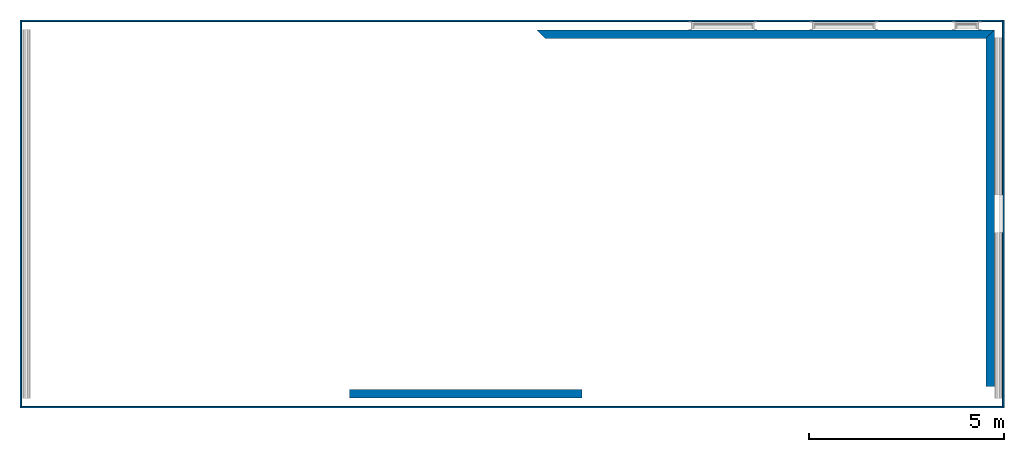
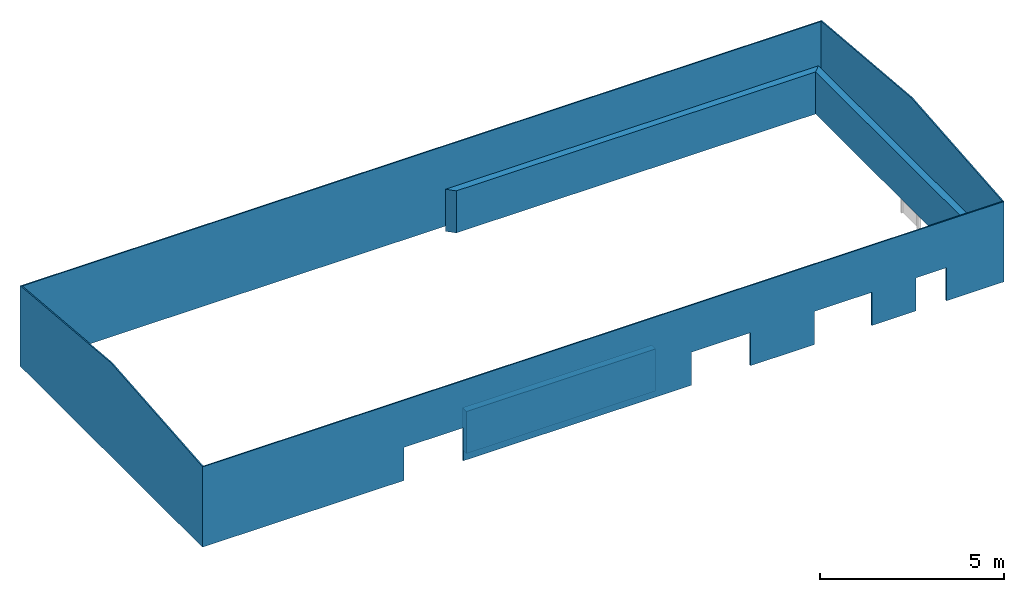
# One storey, part 2 of 4: 7 walls, 8 openings.
"""IFC2X3 building model written with IfcOpenShell, lengths in millimetres."""

from ifc_helpers import new_model, entity, si_unit, converted_unit, money_unit, direction, frame, origin_with_axes, place, context, subcontext, project, spatial, polyline, outline, extrude, clip, halfspace, material, layer, layer_set, layer_usage, type_object, element, save


model = new_model("IFC2X3")

# Units and contexts
model_context = context("Model", 3, precision=1e-05, world=origin_with_axes(), true_north=direction((0.0, 1.0)))
body_context = subcontext(model_context, "Body", "Model", "MODEL_VIEW")
ifc_project = project(units=[si_unit("LENGTHUNIT", "METRE", prefix="MILLI"), si_unit("AREAUNIT", "SQUARE_METRE"), si_unit("VOLUMEUNIT", "CUBIC_METRE"), converted_unit("PLANEANGLEUNIT", "DEGREE", entity("IfcPlaneAngleMeasure", 0.0174532925199), si_unit("PLANEANGLEUNIT", "RADIAN"), dimensions=[0, 0, 0, 0, 0, 0, 0]), si_unit("SOLIDANGLEUNIT", "STERADIAN"), money_unit("USD"), converted_unit("TIMEUNIT", "Year", entity("IfcTimeMeasure", 31556926.0), si_unit("TIMEUNIT", "SECOND"), dimensions=[0, 0, 0, 0, 0, 0, 0]), si_unit("MASSUNIT", "GRAM"), si_unit("THERMODYNAMICTEMPERATUREUNIT", "DEGREE_CELSIUS"), si_unit("LUMINOUSINTENSITYUNIT", "LUMEN")], contexts=[model_context])

# Site, building, storey
site_placement = place(None, origin_with_axes())
site = spatial("IfcSite", under=ifc_project, at=site_placement, CompositionType="ELEMENT")
building_placement = place(site_placement, origin_with_axes())
building = spatial("IfcBuilding", under=site, at=building_placement, CompositionType="ELEMENT")
storey_placement = place(building_placement, frame((0.0, 0.0, 71700.0), z_axis=(0.0, 0.0, 1.0), x_axis=(1.0, 0.0, 0.0)))
storey = spatial("IfcBuildingStorey", under=building, at=storey_placement, CompositionType="ELEMENT", Elevation=71700.0)

# Walls
ifc_material_1 = material(Name="Concrete Masonry Units")
ifc_layer_1 = layer(ifc_material_1, 215.0, ventilated="UNKNOWN")
ifc_layer_set_1 = layer_set([ifc_layer_1], Name="Concrete Masonry Units 215")
ifc_layer_usage_1 = layer_usage(ifc_layer_set_1, "AXIS2", "POSITIVE", -107.5)
wall_type_1 = type_object("IfcWallType", Name="Basic Wall:215mm Thk Solid Blockwork", PredefinedType="STANDARD")
wall_1_placement = place(storey_placement, frame((-6.72084898817, -1030.0200608, 0.0), z_axis=(0.0, 0.0, 1.0), x_axis=(1.0, 0.0, 0.0)))
element("IfcWallStandardCase", 1, at=wall_1_placement, inside=storey, type_object=wall_type_1, material=ifc_layer_usage_1, Name="Basic Wall:215mm Thk Solid Blockwork", ObjectType="Basic Wall:215mm Thk Solid Blockwork", context=body_context, shape_type="SweptSolid", body=[
    extrude(outline(polyline([(0.0, -107.5), (5952.91663758, -107.5), (5952.91663758, 107.5), (0.0, 107.5), (0.0, -107.5)])), origin_with_axes(), (0.0, 0.0, 1.0), 1400.0),
])
ifc_layer_usage_2 = layer_usage(ifc_layer_set_1, "AXIS2", "POSITIVE", -107.5)
wall_2_placement = place(storey_placement, frame((16405.5295383, 8184.98089941, 0.0), z_axis=(0.0, 0.0, 1.0), x_axis=(0.0, -1.0, 0.0)))
element("IfcWallStandardCase", 2, at=wall_2_placement, inside=storey, type_object=wall_type_1, material=ifc_layer_usage_2, Name="Basic Wall:215mm Thk Solid Blockwork", ObjectType="Basic Wall:215mm Thk Solid Blockwork", context=body_context, shape_type="SweptSolid", body=[
    extrude(outline(polyline([(107.5, -107.5), (9028.9009626, -107.5), (9028.9009626, 107.5), (-107.5, 107.5), (107.5, -107.5)])), origin_with_axes(), (0.0, 0.0, 1.0), 1400.0),
])
ifc_layer_usage_3 = layer_usage(ifc_layer_set_1, "AXIS2", "POSITIVE", -107.5)
wall_3_placement = place(storey_placement, frame((4888.27947463, 8184.98089941, 0.0), z_axis=(0.0, 0.0, 1.0), x_axis=(1.0, 0.0, 0.0)))
element("IfcWallStandardCase", 3, at=wall_3_placement, inside=storey, type_object=wall_type_1, material=ifc_layer_usage_3, Name="Basic Wall:215mm Thk Solid Blockwork", ObjectType="Basic Wall:215mm Thk Solid Blockwork", context=body_context, shape_type="SweptSolid", body=[
    extrude(outline(polyline([(107.5, -107.5), (11409.7500637, -107.5), (11624.7500637, 107.5), (-107.5, 107.5), (107.5, -107.5)])), origin_with_axes(), (0.0, 0.0, 1.0), 1400.0),
])

# Wall, opening
ifc_material_2 = material(Name="Cladding, Vertical Ribbed")
ifc_layer_2 = layer(ifc_material_2, 40.0, ventilated="UNKNOWN")
ifc_layer_set_2 = layer_set([ifc_layer_2], Name="Cladding, Vertical Ribbed 40")
ifc_layer_usage_4 = layer_usage(ifc_layer_set_2, "AXIS2", "POSITIVE", -20.0)
wall_type_2 = type_object("IfcWallType", Name="Basic Wall:480mm Cavity Wall KSW Panel 1000", PredefinedType="STANDARD")
wall_4_placement = place(storey_placement, frame((16738.0295383, 8527.27990658, 0.0), z_axis=(0.0, 0.0, 1.0), x_axis=(0.0, -1.0, 0.0)))
wall_4 = element("IfcWallStandardCase", 4, at=wall_4_placement, inside=storey, type_object=wall_type_2, material=ifc_layer_usage_4, Name="Basic Wall:480mm Cavity Wall Panel 1000", ObjectType="Basic Wall:480mm Cavity Wall KSW Panel 1000", context=body_context, shape_type="Clipping", body=[
    clip(clip(extrude(outline(polyline([(20.0, -20.0), (9879.59996977, -20.0), (9919.59996977, 20.0), (-20.0, 20.0), (20.0, -20.0)])), origin_with_axes(), (0.0, 0.0, 1.0), 3115.02217894), halfspace(frame((-232.867655757, 0.0, 2661.68948492), z_axis=(0.0871557427477, 0.0, -0.996194698092), x_axis=(0.0, 1.0, 0.0)), True)), halfspace(frame((308.050269008, 0.0, 3521.03068664), z_axis=(-0.0871557427477, 0.0, -0.996194698092), x_axis=(0.0, 1.0, 0.0)), True)),
])
opening_1_placement = place(wall_4_placement, frame((4949.7999916, 0.0, -1000.0), z_axis=(0.0, 0.0, 1.0), x_axis=(1.0, 0.0, 0.0)))
element("IfcOpeningElement", 5, at=opening_1_placement, cuts=wall_4, Name="Doors_ExtSgl_Flush_Fire_Escape:960x2100mm", context=body_context, shape_type="SweptSolid", body=[
    extrude(outline(polyline([(480.000006706, 0.0), (-480.000006706, 0.0), (-480.000006706, -2100.0), (480.000006706, -2100.0), (480.000006706, 0.0)])), frame((0.0, -20.0, 0.0), z_axis=(0.0, 1.0, 0.0), x_axis=(1.0, 0.0, 0.0)), (0.0, 0.0, 1.0), 40.0),
])

# Wall, openings
ifc_layer_usage_5 = layer_usage(ifc_layer_set_2, "AXIS2", "POSITIVE", -20.0)
wall_5_placement = place(storey_placement, frame((16738.0295383, -1372.32006319, 0.0), z_axis=(0.0, 0.0, 1.0), x_axis=(-1.0, 0.0, 0.0)))
wall_5 = element("IfcWallStandardCase", 6, at=wall_5_placement, inside=storey, type_object=wall_type_2, material=ifc_layer_usage_5, Name="Basic Wall:480mm Cavity Wall Panel 1000", ObjectType="Basic Wall:480mm Cavity Wall KSW Panel 1000", context=body_context, shape_type="SweptSolid", body=[
    extrude(outline(polyline([(20.0, -20.0), (25154.2504249, -20.0), (25194.2504249, 20.0), (-20.0, 20.0), (20.0, -20.0)])), origin_with_axes(), (0.0, 0.0, 1.0), 2670.0),
])
opening_2_placement = place(wall_5_placement, frame((5038.15656623, 0.0, 0.0), z_axis=(0.0, 0.0, 1.0), x_axis=(1.0, 0.0, 0.0)))
element("IfcOpeningElement", 7, at=opening_2_placement, cuts=wall_5, Name="D-001", context=body_context, shape_type="SweptSolid", body=[
    extrude(outline(polyline([(905.0, 1103.5000003), (-905.0, 1103.5000003), (-905.0, 0.0), (905.0, 0.0), (905.0, 1103.5000003)])), frame((0.0, 20.0, 0.0), z_axis=(0.0, -1.0, 0.0), x_axis=(1.0, 0.0, 0.0)), (0.0, 0.0, 1.0), 40.0),
])
opening_3_placement = place(wall_5_placement, frame((8887.13906221, 0.0, 0.0), z_axis=(0.0, 0.0, 1.0), x_axis=(1.0, 0.0, 0.0)))
element("IfcOpeningElement", 8, at=opening_3_placement, cuts=wall_5, Name="D-001", context=body_context, shape_type="SweptSolid", body=[
    extrude(outline(polyline([(930.0, 1100.0), (-930.0, 1100.0), (-930.0, 0.0), (930.0, 0.0), (930.0, 1100.0)])), frame((0.0, 20.0, 0.0), z_axis=(0.0, -1.0, 0.0), x_axis=(1.0, 0.0, 0.0)), (0.0, 0.0, 1.0), 40.0),
])
opening_4_placement = place(wall_5_placement, frame((17917.2504433, 0.0, 0.0), z_axis=(0.0, 0.0, 1.0), x_axis=(1.0, 0.0, 0.0)))
element("IfcOpeningElement", 9, at=opening_4_placement, cuts=wall_5, Name="D-001", context=body_context, shape_type="SweptSolid", body=[
    extrude(outline(polyline([(-930.0, 0.0), (930.0, 0.0), (930.0, 1100.0), (-930.0, 1100.0), (-930.0, 0.0)])), frame((0.0, 20.0, 0.0), z_axis=(0.0, -1.0, 0.0), x_axis=(1.0, 0.0, 0.0)), (0.0, 0.0, 1.0), 40.0),
])
opening_5_placement = place(wall_5_placement, frame((2269.7503873, 0.0, 0.0), z_axis=(0.0, 0.0, 1.0), x_axis=(1.0, 0.0, 0.0)))
element("IfcOpeningElement", 10, at=opening_5_placement, cuts=wall_5, Name="D-001", context=body_context, shape_type="SweptSolid", body=[
    extrude(outline(polyline([(480.0, 1100.0), (-480.0, 1100.0), (-480.0, 0.0), (480.0, 0.0), (480.0, 1100.0)])), frame((0.0, 20.0, 0.0), z_axis=(0.0, -1.0, 0.0), x_axis=(1.0, 0.0, 0.0)), (0.0, 0.0, 1.0), 40.0),
])

# Wall
ifc_layer_usage_6 = layer_usage(ifc_layer_set_2, "AXIS2", "POSITIVE", -20.0)
wall_6_placement = place(storey_placement, frame((-8436.22088657, 8527.27990658, 0.0), z_axis=(0.0, 0.0, 1.0), x_axis=(0.0, -1.0, 0.0)))
element("IfcWallStandardCase", 11, at=wall_6_placement, inside=storey, type_object=wall_type_2, material=ifc_layer_usage_6, Name="Basic Wall:480mm Cavity Wall Panel 1000", ObjectType="Basic Wall:480mm Cavity Wall KSW Panel 1000", context=body_context, shape_type="Clipping", body=[
    clip(clip(extrude(outline(polyline([(-20.0, -20.0), (9919.59996977, -20.0), (9879.59996977, 20.0), (20.0, 20.0), (-20.0, -20.0)])), origin_with_axes(), (0.0, 0.0, 1.0), 3115.02217894), halfspace(frame((-232.867655757, 0.0, 2661.68948492), z_axis=(0.0871557427477, 0.0, -0.996194698092), x_axis=(0.0, 1.0, 0.0)), True)), halfspace(frame((308.050269008, 0.0, 3521.03068664), z_axis=(-0.0871557427477, 0.0, -0.996194698092), x_axis=(0.0, 1.0, 0.0)), True)),
])

# Wall, openings
ifc_layer_usage_7 = layer_usage(ifc_layer_set_2, "AXIS2", "POSITIVE", -20.0)
wall_7_placement = place(storey_placement, frame((16738.0295383, 8527.27990658, 0.0), z_axis=(0.0, 0.0, 1.0), x_axis=(-1.0, 0.0, 0.0)))
wall_7 = element("IfcWallStandardCase", 12, at=wall_7_placement, inside=storey, type_object=wall_type_2, material=ifc_layer_usage_7, Name="Basic Wall:480mm Cavity Wall Panel 1000", ObjectType="Basic Wall:480mm Cavity Wall KSW Panel 1000", context=body_context, shape_type="SweptSolid", body=[
    extrude(outline(polyline([(-20.0, -20.0), (25194.2504249, -20.0), (25154.2504249, 20.0), (20.0, 20.0), (-20.0, -20.0)])), origin_with_axes(), (0.0, 0.0, 1.0), 2670.0),
])
opening_6_placement = place(wall_7_placement, frame((4084.75018512, 0.0, 150.0), z_axis=(0.0, 0.0, 1.0), x_axis=(1.0, 0.0, 0.0)))
element("IfcOpeningElement", 13, at=opening_6_placement, cuts=wall_7, Name="W-001", context=body_context, shape_type="SweptSolid", body=[
    extrude(outline(polyline([(-750.0, 1000.0), (-750.0, 0.0), (750.0, 0.0), (750.0, 1000.0), (-750.0, 1000.0)])), frame((0.0, 20.0, 0.0), z_axis=(0.0, -1.0, 0.0), x_axis=(1.0, 0.0, 0.0)), (0.0, 0.0, 1.0), 40.0),
])
opening_7_placement = place(wall_7_placement, frame((934.750185119, 0.0, 150.0), z_axis=(0.0, 0.0, 1.0), x_axis=(1.0, 0.0, 0.0)))
element("IfcOpeningElement", 14, at=opening_7_placement, cuts=wall_7, Name="W-001", context=body_context, shape_type="SweptSolid", body=[
    extrude(outline(polyline([(-300.0, 1000.0), (-300.0, 0.0), (300.0, 0.0), (300.0, 1000.0), (-300.0, 1000.0)])), frame((0.0, 20.0, 0.0), z_axis=(0.0, -1.0, 0.0), x_axis=(1.0, 0.0, 0.0)), (0.0, 0.0, 1.0), 40.0),
])
opening_8_placement = place(wall_7_placement, frame((7184.75018479, 0.0, 150.0), z_axis=(0.0, 0.0, 1.0), x_axis=(1.0, 0.0, 0.0)))
element("IfcOpeningElement", 15, at=opening_8_placement, cuts=wall_7, Name="W-001", context=body_context, shape_type="SweptSolid", body=[
    extrude(outline(polyline([(-800.0, 1000.0), (-800.0, 0.0), (800.0, 0.0), (800.0, 1000.0), (-800.0, 1000.0)])), frame((0.0, 20.0, 0.0), z_axis=(0.0, -1.0, 0.0), x_axis=(1.0, 0.0, 0.0)), (0.0, 0.0, 1.0), 40.0),
])

save(model, "model.ifc")
